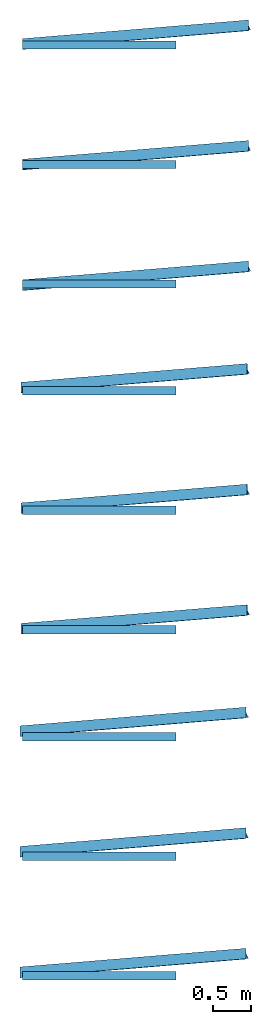
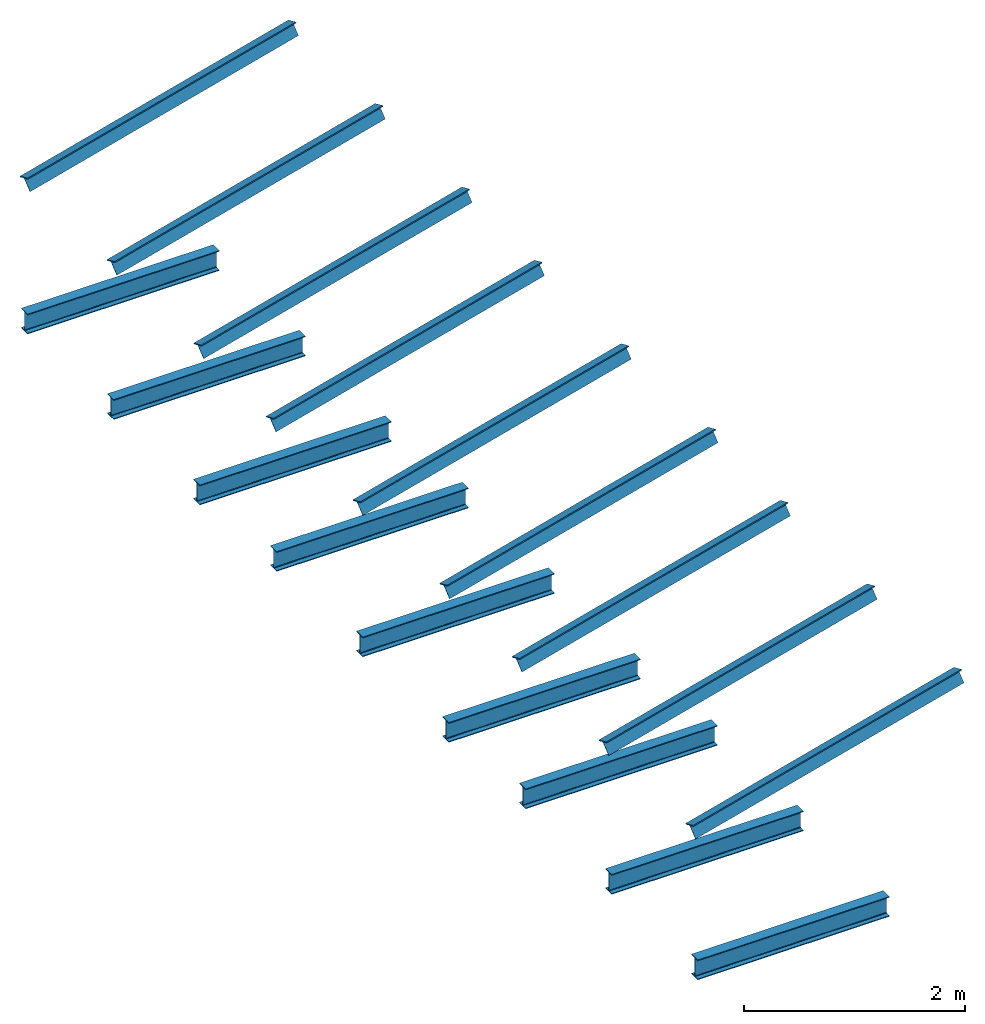
# Not in any storey: 18 beams.
"""IFC4 building model written with IfcOpenShell, lengths in millimetres."""

from ifc_helpers import new_model, si_unit, frame, origin, origin_with_axes, place, context, project, spatial, i_section, t_section, extrude, material, material_profile, profile_set, profile_usage, type_object, element, save


model = new_model("IFC4")

# Units and contexts
model_context = context("Model", 3, precision=1e-05, world=origin_with_axes())
ifc_project = project(units=[si_unit("LENGTHUNIT", "METRE", prefix="MILLI"), si_unit("PLANEANGLEUNIT", "RADIAN"), si_unit("MASSUNIT", "GRAM", prefix="KILO"), si_unit("TIMEUNIT", "SECOND"), si_unit("AREAUNIT", "SQUARE_METRE"), si_unit("PRESSUREUNIT", "PASCAL"), si_unit("FORCEUNIT", "NEWTON"), si_unit("THERMODYNAMICTEMPERATUREUNIT", "DEGREE_CELSIUS")], contexts=[model_context])

# Site, building
site_placement = place(None, origin_with_axes())
site = spatial("IfcSite", under=ifc_project, at=site_placement, CompositionType="ELEMENT")
building_placement = place(site_placement, origin_with_axes())
building = spatial("IfcBuilding", under=site, at=building_placement, Name="Building", CompositionType="ELEMENT")

# Beams
ifc_material_1 = material(Name="S275J2", Category="Steel")
ifc_material_profile_1 = material_profile(ifc_material_1, i_section(OverallWidth=110.0, OverallDepth=220.0, WebThickness=5.9, FlangeThickness=9.2, FilletRadius=12.0), Name="IPE220")
ifc_profile_set_1 = profile_set([ifc_material_profile_1])
ifc_profile_usage_1 = profile_usage(ifc_profile_set_1, cardinal=1)
beam_type_1 = type_object("IfcBeamType", Name="IPE220", PredefinedType="BEAM", material=ifc_profile_set_1)
beam_1_placement = place(building_placement, frame((0.0, 0.0, 0.0), z_axis=(1.0, 0.0, 0.0), x_axis=(0.0, 1.0, 0.0)))
element("IfcBeamStandardCase", 1, at=beam_1_placement, inside=building, type_object=beam_type_1, material=ifc_profile_usage_1, Name="A-1", ObjectType="Beam", context=model_context, shape_type="SweptSolid", body=[
    extrude(i_section(OverallWidth=110.0, OverallDepth=220.0, WebThickness=5.9, FlangeThickness=9.2, FilletRadius=12.0), frame((-55.0, 110.0, 0.0)), (0.0, 0.0, 1.0), 2000.0),
])
ifc_profile_usage_2 = profile_usage(ifc_profile_set_1, cardinal=2)
beam_2_placement = place(building_placement, frame((0.0, 1500.0, 0.0), z_axis=(1.0, 0.0, 0.0), x_axis=(0.0, 1.0, 0.0)))
element("IfcBeamStandardCase", 2, at=beam_2_placement, inside=building, type_object=beam_type_1, material=ifc_profile_usage_2, Name="A-2", ObjectType="Beam", context=model_context, shape_type="SweptSolid", body=[
    extrude(i_section(OverallWidth=110.0, OverallDepth=220.0, WebThickness=5.9, FlangeThickness=9.2, FilletRadius=12.0), frame((0.0, 110.0, 0.0)), (0.0, 0.0, 1.0), 2000.0),
])
ifc_profile_usage_3 = profile_usage(ifc_profile_set_1, cardinal=3)
beam_3_placement = place(building_placement, frame((0.0, 3000.0, 0.0), z_axis=(1.0, 0.0, 0.0), x_axis=(0.0, 1.0, 0.0)))
element("IfcBeamStandardCase", 3, at=beam_3_placement, inside=building, type_object=beam_type_1, material=ifc_profile_usage_3, Name="A-3", ObjectType="Beam", context=model_context, shape_type="SweptSolid", body=[
    extrude(i_section(OverallWidth=110.0, OverallDepth=220.0, WebThickness=5.9, FlangeThickness=9.2, FilletRadius=12.0), frame((55.0, 110.0, 0.0)), (0.0, 0.0, 1.0), 2000.0),
])
ifc_profile_usage_4 = profile_usage(ifc_profile_set_1, cardinal=4)
beam_4_placement = place(building_placement, frame((0.0, 4500.0, 0.0), z_axis=(1.0, 0.0, 0.0), x_axis=(0.0, 1.0, 0.0)))
element("IfcBeamStandardCase", 4, at=beam_4_placement, inside=building, type_object=beam_type_1, material=ifc_profile_usage_4, Name="A-4", ObjectType="Beam", context=model_context, shape_type="SweptSolid", body=[
    extrude(i_section(OverallWidth=110.0, OverallDepth=220.0, WebThickness=5.9, FlangeThickness=9.2, FilletRadius=12.0), frame((-55.0, 0.0, 0.0)), (0.0, 0.0, 1.0), 2000.0),
])
ifc_profile_usage_5 = profile_usage(ifc_profile_set_1, cardinal=5)
beam_5_placement = place(building_placement, frame((0.0, 6000.0, 0.0), z_axis=(1.0, 0.0, 0.0), x_axis=(0.0, 1.0, 0.0)))
element("IfcBeamStandardCase", 5, at=beam_5_placement, inside=building, type_object=beam_type_1, material=ifc_profile_usage_5, Name="A-5", ObjectType="Beam", context=model_context, shape_type="SweptSolid", body=[
    extrude(i_section(OverallWidth=110.0, OverallDepth=220.0, WebThickness=5.9, FlangeThickness=9.2, FilletRadius=12.0), origin(), (0.0, 0.0, 1.0), 2000.0),
])
ifc_profile_usage_6 = profile_usage(ifc_profile_set_1, cardinal=6)
beam_6_placement = place(building_placement, frame((0.0, 7500.0, 0.0), z_axis=(1.0, 0.0, 0.0), x_axis=(0.0, 1.0, 0.0)))
element("IfcBeamStandardCase", 6, at=beam_6_placement, inside=building, type_object=beam_type_1, material=ifc_profile_usage_6, Name="A-6", ObjectType="Beam", context=model_context, shape_type="SweptSolid", body=[
    extrude(i_section(OverallWidth=110.0, OverallDepth=220.0, WebThickness=5.9, FlangeThickness=9.2, FilletRadius=12.0), frame((55.0, 0.0, 0.0)), (0.0, 0.0, 1.0), 2000.0),
])
ifc_profile_usage_7 = profile_usage(ifc_profile_set_1, cardinal=7)
beam_7_placement = place(building_placement, frame((0.0, 9000.0, 0.0), z_axis=(1.0, 0.0, 0.0), x_axis=(0.0, 1.0, 0.0)))
element("IfcBeamStandardCase", 7, at=beam_7_placement, inside=building, type_object=beam_type_1, material=ifc_profile_usage_7, Name="A-7", ObjectType="Beam", context=model_context, shape_type="SweptSolid", body=[
    extrude(i_section(OverallWidth=110.0, OverallDepth=220.0, WebThickness=5.9, FlangeThickness=9.2, FilletRadius=12.0), frame((-55.0, -110.0, 0.0)), (0.0, 0.0, 1.0), 2000.0),
])
ifc_profile_usage_8 = profile_usage(ifc_profile_set_1, cardinal=8)
beam_8_placement = place(building_placement, frame((0.0, 10500.0, 0.0), z_axis=(1.0, 0.0, 0.0), x_axis=(0.0, 1.0, 0.0)))
element("IfcBeamStandardCase", 8, at=beam_8_placement, inside=building, type_object=beam_type_1, material=ifc_profile_usage_8, Name="A-8", ObjectType="Beam", context=model_context, shape_type="SweptSolid", body=[
    extrude(i_section(OverallWidth=110.0, OverallDepth=220.0, WebThickness=5.9, FlangeThickness=9.2, FilletRadius=12.0), frame((0.0, -110.0, 0.0)), (0.0, 0.0, 1.0), 2000.0),
])
ifc_profile_usage_9 = profile_usage(ifc_profile_set_1, cardinal=9)
beam_9_placement = place(building_placement, frame((0.0, 12000.0, 0.0), z_axis=(1.0, 0.0, 0.0), x_axis=(0.0, 1.0, 0.0)))
element("IfcBeamStandardCase", 9, at=beam_9_placement, inside=building, type_object=beam_type_1, material=ifc_profile_usage_9, Name="A-9", ObjectType="Beam", context=model_context, shape_type="SweptSolid", body=[
    extrude(i_section(OverallWidth=110.0, OverallDepth=220.0, WebThickness=5.9, FlangeThickness=9.2, FilletRadius=12.0), frame((55.0, -110.0, 0.0)), (0.0, 0.0, 1.0), 2000.0),
])
ifc_material_2 = material(Name="S275J2", Category="Steel")
ifc_material_profile_2 = material_profile(ifc_material_2, t_section(Depth=150.0, FlangeWidth=150.0, WebThickness=7.1, FlangeThickness=10.7, FilletRadius=15.0), Name="1/2IPE300")
ifc_profile_set_2 = profile_set([ifc_material_profile_2])
ifc_profile_usage_10 = profile_usage(ifc_profile_set_2, cardinal=1)
beam_type_2 = type_object("IfcBeamType", Name="1/2IPE300", PredefinedType="BEAM", material=ifc_profile_set_2)
beam_10_placement = place(building_placement, frame((0.0, 0.0, 1500.0), z_axis=(0.98, 0.081, 0.182), x_axis=(-0.0001, 0.9138, -0.40616)))
element("IfcBeamStandardCase", 10, at=beam_10_placement, inside=building, type_object=beam_type_2, material=ifc_profile_usage_10, Name="B-1", ObjectType="Beam", context=model_context, shape_type="SweptSolid", body=[
    extrude(t_section(Depth=150.0, FlangeWidth=150.0, WebThickness=7.1, FlangeThickness=10.7, FilletRadius=15.0), frame((-75.0, 75.0, 0.0)), (0.0, 0.0, 1.0), 3000.0),
])
ifc_profile_usage_11 = profile_usage(ifc_profile_set_2, cardinal=2)
beam_11_placement = place(building_placement, frame((0.0, 1500.0, 1500.0), z_axis=(0.98, 0.081, 0.182), x_axis=(-0.0001, 0.9138, -0.40616)))
element("IfcBeamStandardCase", 11, at=beam_11_placement, inside=building, type_object=beam_type_2, material=ifc_profile_usage_11, Name="B-2", ObjectType="Beam", context=model_context, shape_type="SweptSolid", body=[
    extrude(t_section(Depth=150.0, FlangeWidth=150.0, WebThickness=7.1, FlangeThickness=10.7, FilletRadius=15.0), frame((0.0, 75.0, 0.0)), (0.0, 0.0, 1.0), 3000.0),
])
ifc_profile_usage_12 = profile_usage(ifc_profile_set_2, cardinal=3)
beam_12_placement = place(building_placement, frame((0.0, 3000.0, 1500.0), z_axis=(0.98, 0.081, 0.182), x_axis=(-0.0001, 0.9138, -0.40616)))
element("IfcBeamStandardCase", 12, at=beam_12_placement, inside=building, type_object=beam_type_2, material=ifc_profile_usage_12, Name="B-3", ObjectType="Beam", context=model_context, shape_type="SweptSolid", body=[
    extrude(t_section(Depth=150.0, FlangeWidth=150.0, WebThickness=7.1, FlangeThickness=10.7, FilletRadius=15.0), frame((75.0, 75.0, 0.0)), (0.0, 0.0, 1.0), 3000.0),
])
ifc_profile_usage_13 = profile_usage(ifc_profile_set_2, cardinal=4)
beam_13_placement = place(building_placement, frame((0.0, 4500.0, 1500.0), z_axis=(0.98, 0.081, 0.182), x_axis=(-0.0001, 0.9138, -0.40616)))
element("IfcBeamStandardCase", 13, at=beam_13_placement, inside=building, type_object=beam_type_2, material=ifc_profile_usage_13, Name="B-4", ObjectType="Beam", context=model_context, shape_type="SweptSolid", body=[
    extrude(t_section(Depth=150.0, FlangeWidth=150.0, WebThickness=7.1, FlangeThickness=10.7, FilletRadius=15.0), frame((-75.0, 0.0, 0.0)), (0.0, 0.0, 1.0), 3000.0),
])
ifc_profile_usage_14 = profile_usage(ifc_profile_set_2, cardinal=5)
beam_14_placement = place(building_placement, frame((0.0, 6000.0, 1500.0), z_axis=(0.98, 0.081, 0.182), x_axis=(-0.0001, 0.9138, -0.40616)))
element("IfcBeamStandardCase", 14, at=beam_14_placement, inside=building, type_object=beam_type_2, material=ifc_profile_usage_14, Name="B-5", ObjectType="Beam", context=model_context, shape_type="SweptSolid", body=[
    extrude(t_section(Depth=150.0, FlangeWidth=150.0, WebThickness=7.1, FlangeThickness=10.7, FilletRadius=15.0), origin(), (0.0, 0.0, 1.0), 3000.0),
])
ifc_profile_usage_15 = profile_usage(ifc_profile_set_2, cardinal=6)
beam_15_placement = place(building_placement, frame((0.0, 7500.0, 1500.0), z_axis=(0.98, 0.081, 0.182), x_axis=(-0.0001, 0.9138, -0.40616)))
element("IfcBeamStandardCase", 15, at=beam_15_placement, inside=building, type_object=beam_type_2, material=ifc_profile_usage_15, Name="B-6", ObjectType="Beam", context=model_context, shape_type="SweptSolid", body=[
    extrude(t_section(Depth=150.0, FlangeWidth=150.0, WebThickness=7.1, FlangeThickness=10.7, FilletRadius=15.0), frame((75.0, 0.0, 0.0)), (0.0, 0.0, 1.0), 3000.0),
])
ifc_profile_usage_16 = profile_usage(ifc_profile_set_2, cardinal=7)
beam_16_placement = place(building_placement, frame((0.0, 9000.0, 1500.0), z_axis=(0.98, 0.081, 0.182), x_axis=(-0.0001, 0.9138, -0.40616)))
element("IfcBeamStandardCase", 16, at=beam_16_placement, inside=building, type_object=beam_type_2, material=ifc_profile_usage_16, Name="B-7", ObjectType="Beam", context=model_context, shape_type="SweptSolid", body=[
    extrude(t_section(Depth=150.0, FlangeWidth=150.0, WebThickness=7.1, FlangeThickness=10.7, FilletRadius=15.0), frame((-75.0, -75.0, 0.0)), (0.0, 0.0, 1.0), 3000.0),
])
ifc_profile_usage_17 = profile_usage(ifc_profile_set_2, cardinal=8)
beam_17_placement = place(building_placement, frame((0.0, 10500.0, 1500.0), z_axis=(0.98, 0.081, 0.182), x_axis=(-0.0001, 0.9138, -0.40616)))
element("IfcBeamStandardCase", 17, at=beam_17_placement, inside=building, type_object=beam_type_2, material=ifc_profile_usage_17, Name="B-8", ObjectType="Beam", context=model_context, shape_type="SweptSolid", body=[
    extrude(t_section(Depth=150.0, FlangeWidth=150.0, WebThickness=7.1, FlangeThickness=10.7, FilletRadius=15.0), frame((0.0, -75.0, 0.0)), (0.0, 0.0, 1.0), 3000.0),
])
ifc_profile_usage_18 = profile_usage(ifc_profile_set_2, cardinal=9)
beam_18_placement = place(building_placement, frame((0.0, 12000.0, 1500.0), z_axis=(0.98, 0.081, 0.182), x_axis=(-0.0001, 0.9138, -0.40616)))
element("IfcBeamStandardCase", 18, at=beam_18_placement, inside=building, type_object=beam_type_2, material=ifc_profile_usage_18, Name="B-9", ObjectType="Beam", context=model_context, shape_type="SweptSolid", body=[
    extrude(t_section(Depth=150.0, FlangeWidth=150.0, WebThickness=7.1, FlangeThickness=10.7, FilletRadius=15.0), frame((75.0, -75.0, 0.0)), (0.0, 0.0, 1.0), 3000.0),
])

save(model, "model.ifc")
